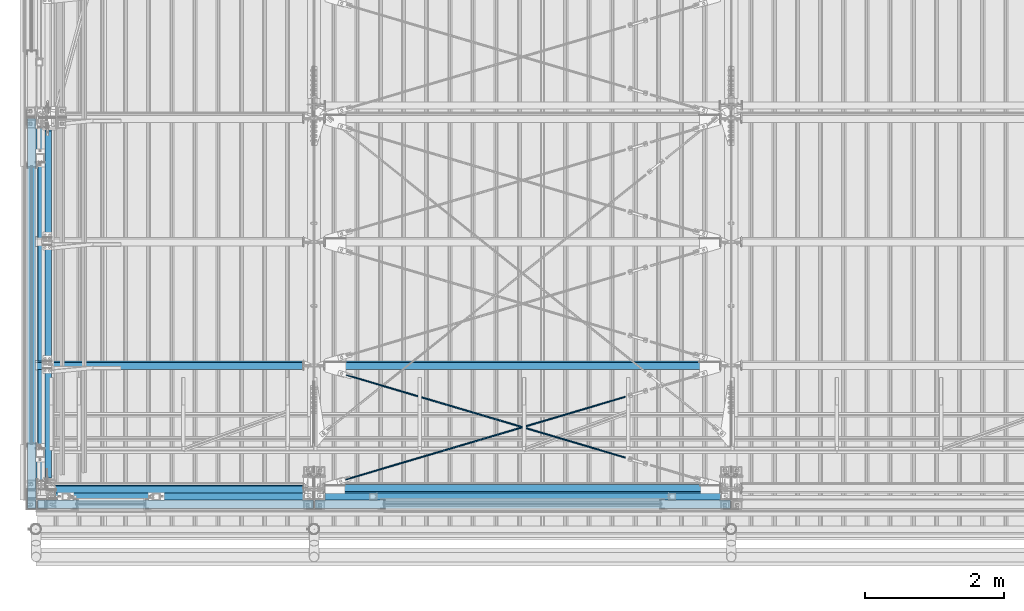
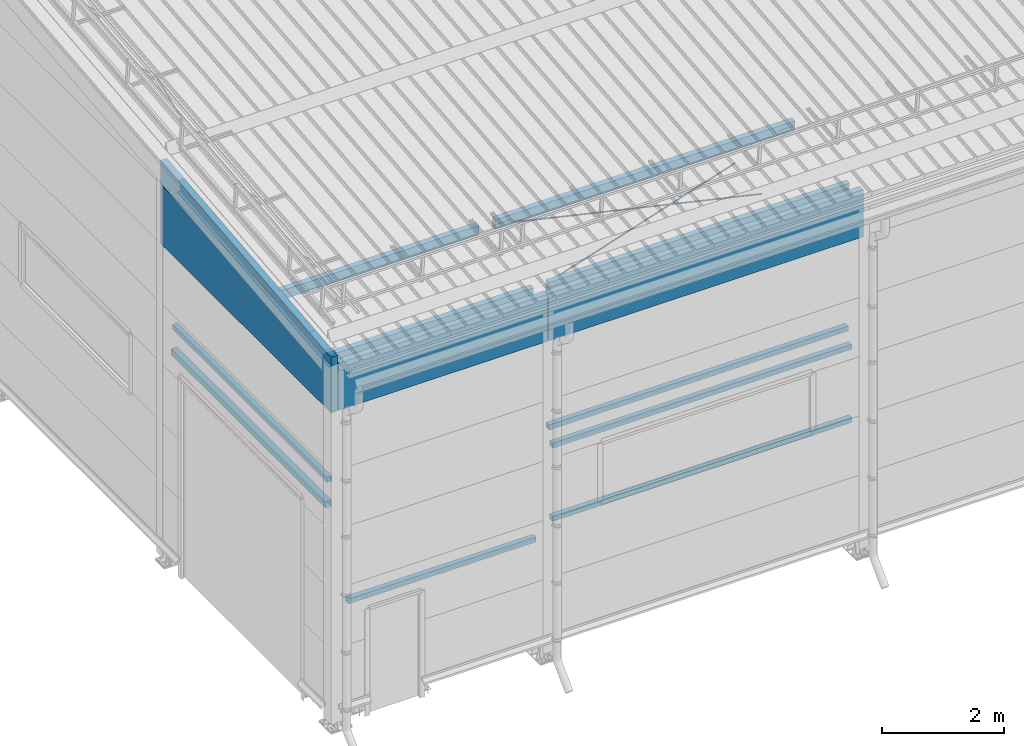
# One storey, part 240 of 709: 17 beams, 6 openings, 17 elements without a shape of their own.
"""IFC4 building model written with IfcOpenShell, lengths in millimetres."""

from ifc_helpers import new_model, si_unit, direction, frame, origin_with_axes, place, context, subcontext, project, spatial, line, indexed_curve, outline, extrude, polygons, material, element, aggregate, save


model = new_model("IFC4")

# Units and contexts
model_context = context("Model", 3, precision=0.2, world=origin_with_axes(), true_north=direction((0.0, 1.0)))
body_context = subcontext(model_context, "Body", "Model", "MODEL_VIEW")
reference_context = subcontext(model_context, "Reference", "Model", "MODEL_VIEW")
ifc_project = project(units=[si_unit("LENGTHUNIT", "METRE", prefix="MILLI"), si_unit("AREAUNIT", "SQUARE_METRE"), si_unit("VOLUMEUNIT", "CUBIC_METRE"), si_unit("MASSUNIT", "GRAM", prefix="KILO"), si_unit("TIMEUNIT", "SECOND"), si_unit("PLANEANGLEUNIT", "RADIAN"), si_unit("SOLIDANGLEUNIT", "STERADIAN"), si_unit("THERMODYNAMICTEMPERATUREUNIT", "DEGREE_CELSIUS"), si_unit("LUMINOUSINTENSITYUNIT", "LUMEN")], contexts=[model_context])

# Site, building, storey
site_placement = place(None, origin_with_axes())
site = spatial("IfcSite", under=ifc_project, at=site_placement, CompositionType="ELEMENT")
building_placement = place(site_placement, origin_with_axes())
building = spatial("IfcBuilding", under=site, at=building_placement, Name="Undefined", CompositionType="ELEMENT")
storey_placement = place(building_placement, origin_with_axes())
storey = spatial("IfcBuildingStorey", under=building, at=storey_placement, Name="Undefined", CompositionType="ELEMENT", Elevation=0.0)

# Assembly, beam
assembly_1_placement = place(storey_placement, frame((162.5, 346.0, 6929.907), z_axis=(1.0, 0.0, 0.0), x_axis=(0.0, 0.9950371902, 0.099503719)))
assembly_1 = element("IfcElementAssembly", 1, at=assembly_1_placement, inside=storey)
ifc_material_1 = material(Name="C255-4", Category="STEEL")
beam_1_placement = place(assembly_1_placement, origin_with_axes())
beam_1 = element("IfcBeam", 2, at=beam_1_placement, material=ifc_material_1, ObjectType="451", context=body_context, shape_type="Tessellation", body=[
    polygons([(-15.12818, -124.0, -62.0), (-15.12818, -116.0, -62.0), (4996.83432, -116.0, -62.0), (4996.83432, -124.0, -62.0), (-15.12818, -116.0, -2.5), (4996.83432, -116.0, -2.5), (-15.12818, 116.0, -2.5), (4996.83432, 116.0, -2.5), (-15.12818, 116.0, -62.0), (4996.83432, 116.0, -62.0), (-15.12818, 124.0, -62.0), (4996.83432, 124.0, -62.0), (-15.12818, 124.0, 62.0), (4996.83432, 124.0, 62.0), (-15.12818, 116.0, 62.0), (4996.83432, 116.0, 62.0), (-15.12818, 116.0, 2.5), (4996.83432, 116.0, 2.5), (-15.12818, -116.0, 2.5), (4996.83432, -116.0, 2.5), (-15.12818, -116.0, 62.0), (4996.83432, -116.0, 62.0), (-15.12818, -124.0, 62.0), (4996.83432, -124.0, 62.0)], [[[1, 2, 3, 4]], [[2, 5, 6, 3]], [[5, 7, 8, 6]], [[7, 9, 10, 8]], [[9, 11, 12, 10]], [[11, 13, 14, 12]], [[13, 15, 16, 14]], [[15, 17, 18, 16]], [[17, 19, 20, 18]], [[19, 21, 22, 20]], [[21, 23, 24, 22]], [[23, 1, 4, 24]], [[6, 8, 10, 12, 14, 16, 18, 20, 22, 24, 4, 3]], [[23, 21, 19, 17, 15, 13, 11, 9, 7, 5, 2, 1]]], closed=True),
])
aggregate(assembly_1, [beam_1])

assembly_2_placement = place(storey_placement, frame((80.0, 5500.0, 4610.0), z_axis=(0.0, 0.0, -1.0), x_axis=(0.0, -1.0, 0.0)))
assembly_2 = element("IfcElementAssembly", 3, at=assembly_2_placement, inside=storey)
ifc_material_2 = material(Name="C355", Category="STEEL")
beam_2_placement = place(assembly_2_placement, origin_with_axes())
beam_2 = element("IfcBeam", 4, at=beam_2_placement, material=ifc_material_2, ObjectType="494", context=body_context, shape_type="Tessellation", body=[
    polygons([(142.5, -50.0, 50.0), (142.5, -50.0, -50.0), (5222.0, -50.0, -50.0), (5222.0, -50.0, 50.0), (142.5, 50.0, 50.0), (5222.0, 50.0, 50.0), (142.5, 50.0, -50.0), (5222.0, 50.0, -50.0), (142.5, -47.0, 47.0), (142.5, 47.0, 47.0), (5222.0, 47.0, 47.0), (5222.0, -47.0, 47.0), (142.5, -47.0, -47.0), (5222.0, -47.0, -47.0), (142.5, 47.0, -47.0), (5222.0, 47.0, -47.0)], [[[1, 2, 3, 4]], [[5, 1, 4, 6]], [[7, 5, 6, 8]], [[2, 7, 8, 3]], [[1, 5, 7, 2], [15, 10, 9, 13]], [[9, 10, 11, 12]], [[13, 9, 12, 14]], [[15, 13, 14, 16]], [[10, 15, 16, 11]], [[3, 8, 6, 4], [14, 12, 11, 16]]], closed=True),
])
aggregate(assembly_2, [beam_2])

assembly_3_placement = place(storey_placement, frame((60.0, 5500.0, 4120.0), z_axis=(0.0, 0.0, -1.0), x_axis=(0.0, -1.0, 0.0)))
assembly_3 = element("IfcElementAssembly", 5, at=assembly_3_placement, inside=storey)
ifc_material_3 = material(Name="C255", Category="STEEL")
beam_3_placement = place(assembly_3_placement, origin_with_axes())
beam_3 = element("IfcBeam", 6, at=beam_3_placement, material=ifc_material_3, ObjectType="531", context=body_context, shape_type="Tessellation", body=[
    polygons([(142.5, -60.0, 60.0), (142.5, -60.0, -60.0), (5222.0, -60.0, -60.0), (5222.0, -60.0, 60.0), (142.5, 60.0, 60.0), (5222.0, 60.0, 60.0), (142.5, 60.0, -60.0), (5222.0, 60.0, -60.0), (142.5, -56.0, 56.0), (142.5, 56.0, 56.0), (5222.0, 56.0, 56.0), (5222.0, -56.0, 56.0), (142.5, -56.0, -56.0), (5222.0, -56.0, -56.0), (142.5, 56.0, -56.0), (5222.0, 56.0, -56.0)], [[[1, 2, 3, 4]], [[5, 1, 4, 6]], [[7, 5, 6, 8]], [[2, 7, 8, 3]], [[1, 5, 7, 2], [15, 10, 9, 13]], [[9, 10, 11, 12]], [[13, 9, 12, 14]], [[15, 13, 14, 16]], [[10, 15, 16, 11]], [[3, 8, 6, 4], [14, 12, 11, 16]]], closed=True),
])
aggregate(assembly_3, [beam_3])

assembly_4_placement = place(storey_placement, frame((80.0, 50.0, 2250.0), z_axis=(0.0, 0.0, -1.0), x_axis=(1.0, 0.0, 0.0)))
assembly_4 = element("IfcElementAssembly", 7, at=assembly_4_placement, inside=storey)
beam_4_placement = place(assembly_4_placement, origin_with_axes())
beam_4 = element("IfcBeam", 8, at=beam_4_placement, material=ifc_material_2, ObjectType="542", context=body_context, shape_type="Tessellation", body=[
    polygons([(3765.0, 50.0, 50.0), (3765.0, 50.0, -50.0), (198.0, 50.0, -50.0), (198.0, 50.0, 50.0), (3765.0, -50.0, 50.0), (198.0, -50.0, 50.0), (3765.0, -50.0, -50.0), (198.0, -50.0, -50.0), (3765.0, 47.0, -47.0), (3765.0, 47.0, 47.0), (198.0, 47.0, 47.0), (198.0, 47.0, -47.0), (3765.0, -47.0, -47.0), (198.0, -47.0, -47.0), (3765.0, -47.0, 47.0), (198.0, -47.0, 47.0)], [[[1, 2, 3, 4]], [[5, 1, 4, 6]], [[7, 5, 6, 8]], [[2, 7, 8, 3]], [[1, 5, 7, 2], [10, 9, 13, 15]], [[9, 10, 11, 12]], [[13, 9, 12, 14]], [[15, 13, 14, 16]], [[10, 15, 16, 11]], [[8, 6, 4, 3], [14, 12, 11, 16]]], closed=True),
])
aggregate(assembly_4, [beam_4])

assembly_5_placement = place(storey_placement, frame((4000.0, 50.0, 2550.0), z_axis=(0.0, 0.0, -1.0), x_axis=(1.0, 0.0, 0.0)))
assembly_5 = element("IfcElementAssembly", 9, at=assembly_5_placement, inside=storey)
beam_5_placement = place(assembly_5_placement, origin_with_axes())
beam_5 = element("IfcBeam", 10, at=beam_5_placement, material=ifc_material_2, ObjectType="545", context=body_context, shape_type="Tessellation", body=[
    polygons([(155.0, -47.0, -47.0), (155.0, -47.0, 47.0), (5845.0, -47.0, 47.0), (5845.0, -47.0, -47.0), (155.0, 47.0, 47.0), (5845.0, 47.0, 47.0), (155.0, 47.0, -47.0), (5845.0, 47.0, -47.0), (155.0, -50.0, -50.0), (155.0, 50.0, -50.0), (5845.0, 50.0, -50.0), (5845.0, -50.0, -50.0), (155.0, 50.0, 50.0), (5845.0, 50.0, 50.0), (155.0, -50.0, 50.0), (5845.0, -50.0, 50.0)], [[[1, 2, 3, 4]], [[2, 5, 6, 3]], [[5, 7, 8, 6]], [[7, 1, 4, 8]], [[9, 10, 11, 12]], [[10, 13, 14, 11]], [[13, 15, 16, 14]], [[15, 9, 12, 16]], [[14, 16, 12, 11], [6, 8, 4, 3]], [[15, 13, 10, 9], [7, 5, 2, 1]]], closed=True),
])
aggregate(assembly_5, [beam_5])

assembly_6_placement = place(storey_placement, frame((4000.0, 50.0, 4020.0), z_axis=(0.0, 0.0, -1.0), x_axis=(1.0, 0.0, 0.0)))
assembly_6 = element("IfcElementAssembly", 11, at=assembly_6_placement, inside=storey)
beam_6_placement = place(assembly_6_placement, origin_with_axes())
beam_6 = element("IfcBeam", 12, at=beam_6_placement, material=ifc_material_2, ObjectType="545", context=body_context, shape_type="Tessellation", body=[
    polygons([(155.0, -47.0, -47.0), (155.0, -47.0, 47.0), (5845.0, -47.0, 47.0), (5845.0, -47.0, -47.0), (155.0, 47.0, 47.0), (5845.0, 47.0, 47.0), (155.0, 47.0, -47.0), (5845.0, 47.0, -47.0), (155.0, -50.0, -50.0), (155.0, 50.0, -50.0), (5845.0, 50.0, -50.0), (5845.0, -50.0, -50.0), (155.0, 50.0, 50.0), (5845.0, 50.0, 50.0), (155.0, -50.0, 50.0), (5845.0, -50.0, 50.0)], [[[1, 2, 3, 4]], [[2, 5, 6, 3]], [[5, 7, 8, 6]], [[7, 1, 4, 8]], [[9, 10, 11, 12]], [[10, 13, 14, 11]], [[13, 15, 16, 14]], [[15, 9, 12, 16]], [[14, 16, 12, 11], [6, 8, 4, 3]], [[15, 13, 10, 9], [7, 5, 2, 1]]], closed=True),
])
aggregate(assembly_6, [beam_6])

assembly_7_placement = place(storey_placement, frame((4000.0, 173.0, 4310.0), z_axis=(0.0, 0.0, -1.0), x_axis=(1.0, 0.0, 0.0)))
assembly_7 = element("IfcElementAssembly", 13, at=assembly_7_placement, inside=storey)
beam_7_placement = place(assembly_7_placement, origin_with_axes())
beam_7 = element("IfcBeam", 14, at=beam_7_placement, material=ifc_material_2, ObjectType="546", context=body_context, shape_type="Tessellation", body=[
    polygons([(155.0, -47.0, -47.0), (155.0, -47.0, 47.0), (5845.0, -47.0, 47.0), (5845.0, -47.0, -47.0), (155.0, 47.0, 47.0), (5845.0, 47.0, 47.0), (155.0, 47.0, -47.0), (5845.0, 47.0, -47.0), (155.0, -50.0, -50.0), (155.0, 50.0, -50.0), (5845.0, 50.0, -50.0), (5845.0, -50.0, -50.0), (155.0, 50.0, 50.0), (5845.0, 50.0, 50.0), (155.0, -50.0, 50.0), (5845.0, -50.0, 50.0)], [[[1, 2, 3, 4]], [[2, 5, 6, 3]], [[5, 7, 8, 6]], [[7, 1, 4, 8]], [[9, 10, 11, 12]], [[10, 13, 14, 11]], [[13, 15, 16, 14]], [[15, 9, 12, 16]], [[14, 16, 12, 11], [6, 8, 4, 3]], [[15, 13, 10, 9], [7, 5, 2, 1]]], closed=True),
])
aggregate(assembly_7, [beam_7])

# Assembly, beam, voiding feature
assembly_8_placement = place(storey_placement, frame((4000.0, 159.15434, 7152.41945), z_axis=(0.2852311229, -0.9537021177, -0.0953702118), x_axis=(0.9584587662, 0.2838155751, 0.028381558)))
assembly_8 = element("IfcElementAssembly", 15, at=assembly_8_placement, inside=storey)
ifc_material_4 = material(Name="C355-5", Category="STEEL")
beam_8_placement = place(assembly_8_placement, origin_with_axes())
beam_8 = element("IfcBeam", 16, at=beam_8_placement, material=ifc_material_4, ObjectType="568", context=body_context, shape_type="Tessellation", body=[
    polygons([(4850.05021, 7.36121, 4.25), (4850.05021, 6.01041, 6.01041), (4850.05021, 4.25, 7.36122), (4850.05021, 2.19996, 8.21037), (4850.05021, 0.0, 8.5), (4850.05021, -2.19996, 8.21037), (4850.05021, -4.25, 7.36122), (4850.05021, -6.01041, 6.01041), (4850.05021, -7.36122, 4.25), (4850.05021, -8.21037, 2.19996), (4850.05021, -8.5, 0.0), (4850.05021, -8.21037, -2.19996), (4850.05021, -7.36122, -4.25), (4850.05021, -6.01041, -6.01041), (4850.05021, -4.25, -7.36121), (4850.05021, -2.19996, -8.21037), (4850.05021, 0.0, -8.5), (4850.05021, 2.19996, -8.21037), (4850.05021, 4.25, -7.36121), (4850.05021, 6.01041, -6.01041), (4850.05021, 7.36121, -4.25), (4850.05021, 8.21037, -2.19996), (4850.05021, 8.5, 0.0), (4850.05021, 8.21037, 2.19996), (4670.05021, 8.21037, 2.19996), (4670.05021, 7.36121, 4.25), (4670.05021, 6.01041, 6.01041), (4670.05021, 4.25, 7.36122), (4670.05021, 2.19996, 8.21037), (4670.05021, 0.0, 8.5), (4670.05021, -2.19996, 8.21037), (4670.05021, -4.25, 7.36122), (4670.05021, -6.01041, 6.01041), (4670.05021, -7.36122, 4.25), (4670.05021, -8.21037, 2.19996), (4670.05021, -8.5, 0.0), (4670.05021, -8.21037, -2.19996), (4670.05021, -7.36122, -4.25), (4670.05021, -6.01041, -6.01041), (4670.05021, -4.25, -7.36121), (4670.05021, -2.19996, -8.21037), (4670.05021, 0.0, -8.5), (4670.05021, 2.19996, -8.21037), (4670.05021, 4.25, -7.36121), (4670.05021, 6.01041, -6.01041), (4670.05021, 7.36121, -4.25), (4670.05021, 8.21037, -2.19996), (4670.05021, 8.5, 0.0), (4670.05021, 10.0, 0.0), (4670.05021, 9.65926, 2.58819), (4670.05021, 8.66025, 5.0), (4670.05021, 7.07107, 7.07107), (4670.05021, 5.0, 8.66025), (4670.05021, 2.58819, 9.65926), (4670.05021, 0.0, 10.0), (4670.05021, -2.58819, 9.65926), (4670.05021, -5.0, 8.66025), (4670.05021, -7.07107, 7.07107), (4670.05021, -8.66025, 5.0), (4670.05021, -9.65926, 2.58819), (4670.05021, -10.0, 0.0), (4670.05021, -9.65926, -2.58819), (4670.05021, -8.66025, -5.0), (4670.05021, -7.07107, -7.07107), (4670.05021, -5.0, -8.66025), (4670.05021, -2.58819, -9.65926), (4670.05021, 0.0, -10.0), (4670.05021, 2.58819, -9.65926), (4670.05021, 5.0, -8.66025), (4670.05021, 7.07107, -7.07107), (4670.05021, 8.66025, -5.0), (4670.05021, 9.65926, -2.58819), (468.0251, 2.58819, 9.65926), (468.0251, 5.0, 8.66025), (468.0251, 7.07107, 7.07107), (468.0251, 8.66025, 5.0), (468.0251, 9.65926, 2.58819), (468.0251, 10.0, 0.0), (468.0251, 9.65926, -2.58819), (468.0251, 8.66025, -5.0), (468.0251, 7.07107, -7.07107), (468.0251, 5.0, -8.66025), (468.0251, 2.58819, -9.65926), (468.0251, 0.0, -10.0), (468.0251, -2.58819, -9.65926), (468.0251, -5.0, -8.66025), (468.0251, -7.07107, -7.07107), (468.0251, -8.66025, -5.0), (468.0251, -9.65926, -2.58819), (468.0251, -10.0, 0.0), (468.0251, -9.65926, 2.58819), (468.0251, -8.66025, 5.0), (468.0251, -7.07107, 7.07107), (468.0251, -5.0, 8.66025), (468.0251, -2.58819, 9.65926), (468.0251, 0.0, 10.0)], [[[1, 2, 3, 4, 5, 6, 7, 8, 9, 10, 11, 12, 13, 14, 15, 16, 17, 18, 19, 20, 21, 22, 23, 24]], [[24, 25, 26, 1]], [[1, 26, 27, 2]], [[2, 27, 28, 3]], [[3, 28, 29, 4]], [[4, 29, 30, 5]], [[5, 30, 31, 6]], [[6, 31, 32, 7]], [[7, 32, 33, 8]], [[8, 33, 34, 9]], [[9, 34, 35, 10]], [[10, 35, 36, 11]], [[11, 36, 37, 12]], [[12, 37, 38, 13]], [[13, 38, 39, 14]], [[14, 39, 40, 15]], [[15, 40, 41, 16]], [[16, 41, 42, 17]], [[17, 42, 43, 18]], [[18, 43, 44, 19]], [[19, 44, 45, 20]], [[20, 45, 46, 21]], [[21, 46, 47, 22]], [[22, 47, 48, 23]], [[23, 48, 25, 24]], [[49, 50, 51, 52, 53, 54, 55, 56, 57, 58, 59, 60, 61, 62, 63, 64, 65, 66, 67, 68, 69, 70, 71, 72], [47, 46, 45, 44, 43, 42, 41, 40, 39, 38, 37, 36, 35, 34, 33, 32, 31, 30, 29, 28, 27, 26, 25, 48]], [[73, 74, 75, 76, 77, 78, 79, 80, 81, 82, 83, 84, 85, 86, 87, 88, 89, 90, 91, 92, 93, 94, 95, 96]], [[79, 78, 49, 72]], [[80, 79, 72, 71]], [[81, 80, 71, 70]], [[82, 81, 70, 69]], [[83, 82, 69, 68]], [[84, 83, 68, 67]], [[85, 84, 67, 66]], [[86, 85, 66, 65]], [[87, 86, 65, 64]], [[88, 87, 64, 63]], [[89, 88, 63, 62]], [[90, 89, 62, 61]], [[91, 90, 61, 60]], [[92, 91, 60, 59]], [[93, 92, 59, 58]], [[94, 93, 58, 57]], [[95, 94, 57, 56]], [[96, 95, 56, 55]], [[73, 96, 55, 54]], [[74, 73, 54, 53]], [[75, 74, 53, 52]], [[76, 75, 52, 51]], [[77, 76, 51, 50]], [[78, 77, 50, 49]]], closed=True),
])
voiding_feature_1_placement = place(beam_8_placement, frame((4850.05021, 0.0, 0.0), z_axis=(0.0, 1.0, 0.0), x_axis=(-1.0, 0.0, 0.0)))
element("IfcVoidingFeature", 17, at=voiding_feature_1_placement, cuts=beam_8, PredefinedType="HOLE", context=reference_context, identifier="Reference", shape_type="SolidModel", body=[
    extrude(outline(indexed_curve([(10.5, 0.0), (10.14222, 2.7176), (9.09327, 5.25), (7.42462, 7.42462), (5.25, 9.09327), (2.7176, 10.14222), (0.0, 10.5), (-2.7176, 10.14222), (-5.25, 9.09327), (-7.42462, 7.42462), (-9.09327, 5.25), (-10.14222, 2.7176), (-10.5, 0.0), (-10.14222, -2.7176), (-9.09327, -5.25), (-7.42462, -7.42462), (-5.25, -9.09327), (-2.7176, -10.14222), (0.0, -10.5), (2.7176, -10.14222), (5.25, -9.09327), (7.42462, -7.42462), (9.09327, -5.25), (10.14222, -2.7176)], segments=[line(1, 2, 3, 4, 5, 6, 7, 8, 9, 10, 11, 12, 13, 14, 15, 16, 17, 18, 19, 20, 21, 22, 23, 24, 1)])), frame((0.0, 0.0, 0.0), z_axis=(-1.0, 0.0, 0.0), x_axis=(0.0, 0.0, 1.0)), (0.0, 0.0, -1.0), 180.0),
])
aggregate(assembly_8, [beam_8])

assembly_9_placement = place(storey_placement, frame((4000.0, 1935.85409, 7330.08943), z_axis=(-0.2852311229, -0.9537021177, -0.0953702118), x_axis=(0.9584587662, -0.2838155751, -0.028381558)))
assembly_9 = element("IfcElementAssembly", 18, at=assembly_9_placement, inside=storey)
beam_9_placement = place(assembly_9_placement, origin_with_axes())
beam_9 = element("IfcBeam", 19, at=beam_9_placement, material=ifc_material_4, ObjectType="570", context=body_context, shape_type="Tessellation", body=[
    polygons([(4850.05021, 7.36122, 4.25), (4850.05021, 6.01041, 6.01041), (4850.05021, 4.25, 7.36121), (4850.05021, 2.19996, 8.21037), (4850.05021, 0.0, 8.5), (4850.05021, -2.19996, 8.21037), (4850.05021, -4.25, 7.36121), (4850.05021, -6.01041, 6.01041), (4850.05021, -7.36121, 4.25), (4850.05021, -8.21037, 2.19996), (4850.05021, -8.5, 0.0), (4850.05021, -8.21037, -2.19996), (4850.05021, -7.36121, -4.25), (4850.05021, -6.01041, -6.01041), (4850.05021, -4.25, -7.36122), (4850.05021, -2.19996, -8.21037), (4850.05021, 0.0, -8.5), (4850.05021, 2.19996, -8.21037), (4850.05021, 4.25, -7.36122), (4850.05021, 6.01041, -6.01041), (4850.05021, 7.36122, -4.25), (4850.05021, 8.21037, -2.19996), (4850.05021, 8.5, 0.0), (4850.05021, 8.21037, 2.19996), (4670.05021, 8.21037, 2.19996), (4670.05021, 7.36122, 4.25), (4670.05021, 6.01041, 6.01041), (4670.05021, 4.25, 7.36121), (4670.05021, 2.19996, 8.21037), (4670.05021, 0.0, 8.5), (4670.05021, -2.19996, 8.21037), (4670.05021, -4.25, 7.36121), (4670.05021, -6.01041, 6.01041), (4670.05021, -7.36121, 4.25), (4670.05021, -8.21037, 2.19996), (4670.05021, -8.5, 0.0), (4670.05021, -8.21037, -2.19996), (4670.05021, -7.36121, -4.25), (4670.05021, -6.01041, -6.01041), (4670.05021, -4.25, -7.36122), (4670.05021, -2.19996, -8.21037), (4670.05021, 0.0, -8.5), (4670.05021, 2.19996, -8.21037), (4670.05021, 4.25, -7.36122), (4670.05021, 6.01041, -6.01041), (4670.05021, 7.36122, -4.25), (4670.05021, 8.21037, -2.19996), (4670.05021, 8.5, 0.0), (4670.05021, 10.0, 0.0), (4670.05021, 9.65926, 2.58819), (4670.05021, 8.66025, 5.0), (4670.05021, 7.07107, 7.07107), (4670.05021, 5.0, 8.66025), (4670.05021, 2.58819, 9.65926), (4670.05021, 0.0, 10.0), (4670.05021, -2.58819, 9.65926), (4670.05021, -5.0, 8.66025), (4670.05021, -7.07107, 7.07107), (4670.05021, -8.66025, 5.0), (4670.05021, -9.65926, 2.58819), (4670.05021, -10.0, 0.0), (4670.05021, -9.65926, -2.58819), (4670.05021, -8.66025, -5.0), (4670.05021, -7.07107, -7.07107), (4670.05021, -5.0, -8.66025), (4670.05021, -2.58819, -9.65926), (4670.05021, 0.0, -10.0), (4670.05021, 2.58819, -9.65926), (4670.05021, 5.0, -8.66025), (4670.05021, 7.07107, -7.07107), (4670.05021, 8.66025, -5.0), (4670.05021, 9.65926, -2.58819), (483.0251, 2.58819, 9.65926), (483.0251, 5.0, 8.66025), (483.0251, 7.07107, 7.07107), (483.0251, 8.66025, 5.0), (483.0251, 9.65926, 2.58819), (483.0251, 10.0, 0.0), (483.0251, 9.65926, -2.58819), (483.0251, 8.66025, -5.0), (483.0251, 7.07107, -7.07107), (483.0251, 5.0, -8.66025), (483.0251, 2.58819, -9.65926), (483.0251, 0.0, -10.0), (483.0251, -2.58819, -9.65926), (483.0251, -5.0, -8.66025), (483.0251, -7.07107, -7.07107), (483.0251, -8.66025, -5.0), (483.0251, -9.65926, -2.58819), (483.0251, -10.0, 0.0), (483.0251, -9.65926, 2.58819), (483.0251, -8.66025, 5.0), (483.0251, -7.07107, 7.07107), (483.0251, -5.0, 8.66025), (483.0251, -2.58819, 9.65926), (483.0251, 0.0, 10.0)], [[[1, 2, 3, 4, 5, 6, 7, 8, 9, 10, 11, 12, 13, 14, 15, 16, 17, 18, 19, 20, 21, 22, 23, 24]], [[24, 25, 26, 1]], [[1, 26, 27, 2]], [[2, 27, 28, 3]], [[3, 28, 29, 4]], [[4, 29, 30, 5]], [[5, 30, 31, 6]], [[6, 31, 32, 7]], [[7, 32, 33, 8]], [[8, 33, 34, 9]], [[9, 34, 35, 10]], [[10, 35, 36, 11]], [[11, 36, 37, 12]], [[12, 37, 38, 13]], [[13, 38, 39, 14]], [[14, 39, 40, 15]], [[15, 40, 41, 16]], [[16, 41, 42, 17]], [[17, 42, 43, 18]], [[18, 43, 44, 19]], [[19, 44, 45, 20]], [[20, 45, 46, 21]], [[21, 46, 47, 22]], [[22, 47, 48, 23]], [[23, 48, 25, 24]], [[49, 50, 51, 52, 53, 54, 55, 56, 57, 58, 59, 60, 61, 62, 63, 64, 65, 66, 67, 68, 69, 70, 71, 72], [47, 46, 45, 44, 43, 42, 41, 40, 39, 38, 37, 36, 35, 34, 33, 32, 31, 30, 29, 28, 27, 26, 25, 48]], [[73, 74, 75, 76, 77, 78, 79, 80, 81, 82, 83, 84, 85, 86, 87, 88, 89, 90, 91, 92, 93, 94, 95, 96]], [[79, 78, 49, 72]], [[80, 79, 72, 71]], [[81, 80, 71, 70]], [[82, 81, 70, 69]], [[83, 82, 69, 68]], [[84, 83, 68, 67]], [[85, 84, 67, 66]], [[86, 85, 66, 65]], [[87, 86, 65, 64]], [[88, 87, 64, 63]], [[89, 88, 63, 62]], [[90, 89, 62, 61]], [[91, 90, 61, 60]], [[92, 91, 60, 59]], [[93, 92, 59, 58]], [[94, 93, 58, 57]], [[95, 94, 57, 56]], [[96, 95, 56, 55]], [[73, 96, 55, 54]], [[74, 73, 54, 53]], [[75, 74, 53, 52]], [[76, 75, 52, 51]], [[77, 76, 51, 50]], [[78, 77, 50, 49]]], closed=True),
])
voiding_feature_2_placement = place(beam_9_placement, frame((4850.05021, 0.0, 0.0), z_axis=(0.0, 1.0, 0.0), x_axis=(-1.0, 0.0, 0.0)))
element("IfcVoidingFeature", 20, at=voiding_feature_2_placement, cuts=beam_9, PredefinedType="HOLE", context=reference_context, identifier="Reference", shape_type="SolidModel", body=[
    extrude(outline(indexed_curve([(10.5, 0.0), (10.14222, 2.7176), (9.09327, 5.25), (7.42462, 7.42462), (5.25, 9.09327), (2.7176, 10.14222), (0.0, 10.5), (-2.7176, 10.14222), (-5.25, 9.09327), (-7.42462, 7.42462), (-9.09327, 5.25), (-10.14222, 2.7176), (-10.5, 0.0), (-10.14222, -2.7176), (-9.09327, -5.25), (-7.42462, -7.42462), (-5.25, -9.09327), (-2.7176, -10.14222), (0.0, -10.5), (2.7176, -10.14222), (5.25, -9.09327), (7.42462, -7.42462), (9.09327, -5.25), (10.14222, -2.7176)], segments=[line(1, 2, 3, 4, 5, 6, 7, 8, 9, 10, 11, 12, 13, 14, 15, 16, 17, 18, 19, 20, 21, 22, 23, 24, 1)])), frame((0.0, 0.0, 0.0), z_axis=(-1.0, 0.0, 0.0), x_axis=(0.0, 0.0, 1.0)), (0.0, 0.0, -1.0), 180.0),
])
aggregate(assembly_9, [beam_9])

# Assembly, beam
assembly_10_placement = place(storey_placement, frame((0.0, 159.95037, 7144.41925), z_axis=(0.0, 0.9950371902, 0.099503719), x_axis=(1.0, 0.0, 0.0)))
assembly_10 = element("IfcElementAssembly", 21, at=assembly_10_placement, inside=storey)
beam_10_placement = place(assembly_10_placement, origin_with_axes())
beam_10 = element("IfcBeam", 22, at=beam_10_placement, material=ifc_material_2, ObjectType="562", context=body_context, shape_type="Tessellation", body=[
    polygons([(3855.0, 100.0, 50.0), (3855.0, 100.0, -50.0), (28.0, 100.0, -50.0), (28.0, 100.0, 50.0), (3855.0, -100.0, 50.0), (28.0, -100.0, 50.0), (3855.0, -100.0, -50.0), (28.0, -100.0, -50.0), (3855.0, 96.0, -46.0), (3855.0, 96.0, 46.0), (28.0, 96.0, 46.0), (28.0, 96.0, -46.0), (3855.0, -96.0, -46.0), (28.0, -96.0, -46.0), (3855.0, -96.0, 46.0), (28.0, -96.0, 46.0)], [[[1, 2, 3, 4]], [[5, 1, 4, 6]], [[7, 5, 6, 8]], [[2, 7, 8, 3]], [[1, 5, 7, 2], [10, 9, 13, 15]], [[9, 10, 11, 12]], [[13, 9, 12, 14]], [[15, 13, 14, 16]], [[10, 15, 16, 11]], [[8, 6, 4, 3], [14, 12, 11, 16]]], closed=True),
])
aggregate(assembly_10, [beam_10])

assembly_11_placement = place(storey_placement, frame((0.0, 1936.65012, 7322.08923), z_axis=(0.0, 0.9950371902, 0.099503719), x_axis=(1.0, 0.0, 0.0)))
assembly_11 = element("IfcElementAssembly", 23, at=assembly_11_placement, inside=storey)
beam_11_placement = place(assembly_11_placement, origin_with_axes())
beam_11 = element("IfcBeam", 24, at=beam_11_placement, material=ifc_material_2, ObjectType="563", context=body_context, shape_type="Tessellation", body=[
    polygons([(3845.0, 100.0, 50.0), (3845.0, 100.0, -50.0), (8.0, 100.0, -50.0), (8.0, 100.0, 50.0), (3845.0, -100.0, 50.0), (8.0, -100.0, 50.0), (3845.0, -100.0, -50.0), (8.0, -100.0, -50.0), (3845.0, 96.0, -46.0), (3845.0, 96.0, 46.0), (8.0, 96.0, 46.0), (8.0, 96.0, -46.0), (3845.0, -96.0, -46.0), (8.0, -96.0, -46.0), (3845.0, -96.0, 46.0), (8.0, -96.0, 46.0)], [[[1, 2, 3, 4]], [[5, 1, 4, 6]], [[7, 5, 6, 8]], [[2, 7, 8, 3]], [[1, 5, 7, 2], [10, 9, 13, 15]], [[9, 10, 11, 12]], [[13, 9, 12, 14]], [[15, 13, 14, 16]], [[10, 15, 16, 11]], [[8, 6, 4, 3], [14, 12, 11, 16]]], closed=True),
])
aggregate(assembly_11, [beam_11])

# Assembly, beam, voiding features
assembly_12_placement = place(storey_placement, frame((4000.0, 158.95533, 7154.40952), z_axis=(0.0, 0.9950371902, 0.099503719), x_axis=(1.0, 0.0, 0.0)))
assembly_12 = element("IfcElementAssembly", 25, at=assembly_12_placement, inside=storey)
beam_12_placement = place(assembly_12_placement, origin_with_axes())
beam_12 = element("IfcBeam", 26, at=beam_12_placement, material=ifc_material_2, ObjectType="565", context=body_context, shape_type="Tessellation", body=[
    polygons([(5855.0, 5.0, 50.0), (5855.0, 5.0, 46.0), (5557.75102, 5.0, 46.0), (5557.75102, 5.0, 50.0), (5557.75102, 15.0, 46.0), (5557.75102, 15.0, 50.0), (5855.0, 15.0, 50.0), (5855.0, 15.0, 46.0), (5855.0, 5.0, -46.0), (5855.0, 5.0, -50.0), (5557.75102, 5.0, -50.0), (5557.75102, 5.0, -46.0), (5557.75102, 15.0, -50.0), (5557.75102, 15.0, -46.0), (5855.0, 15.0, -46.0), (5855.0, 15.0, -50.0), (145.0, 86.0, 46.0), (145.0, 86.0, -46.0), (5855.0, 86.0, -46.0), (5855.0, 86.0, 46.0), (5855.0, -86.0, 46.0), (145.0, -86.0, 46.0), (145.0, 5.0, 46.0), (442.24898, 5.0, 46.0), (442.24898, 15.0, 46.0), (145.0, 15.0, 46.0), (145.0, -86.0, -46.0), (5855.0, -86.0, -46.0), (145.0, 15.0, -46.0), (145.0, 15.0, -50.0), (442.24898, 15.0, -50.0), (442.24898, 15.0, -46.0), (442.24898, 5.0, -50.0), (442.24898, 5.0, -46.0), (145.0, 5.0, -50.0), (145.0, 5.0, -46.0), (145.0, -90.0, -50.0), (145.0, -90.0, 50.0), (145.0, 5.0, 50.0), (442.24898, 5.0, 50.0), (442.24898, 15.0, 50.0), (145.0, 15.0, 50.0), (145.0, 90.0, 50.0), (145.0, 90.0, -50.0), (5855.0, 90.0, 50.0), (5855.0, 90.0, -50.0), (5855.0, -90.0, -50.0), (5855.0, -90.0, 50.0)], [[[1, 2, 3, 4]], [[4, 3, 5, 6]], [[7, 6, 5, 8]], [[9, 10, 11, 12]], [[12, 11, 13, 14]], [[15, 14, 13, 16]], [[17, 18, 19, 20]], [[3, 2, 21, 22, 23, 24, 25, 26, 17, 20, 8, 5]], [[27, 22, 21, 28]], [[29, 30, 31, 32]], [[32, 31, 33, 34]], [[34, 33, 35, 36]], [[22, 27, 36, 35, 37, 38, 39, 23]], [[40, 24, 23, 39]], [[41, 25, 24, 40]], [[42, 26, 25, 41]], [[43, 44, 30, 29, 18, 17, 26, 42]], [[44, 43, 45, 46]], [[20, 19, 15, 16, 46, 45, 7, 8]], [[11, 10, 47, 37, 35, 33, 31, 30, 44, 46, 16, 13]], [[38, 37, 47, 48]], [[45, 43, 42, 41, 40, 39, 38, 48, 1, 4, 6, 7]], [[48, 47, 10, 9, 28, 21, 2, 1]], [[19, 18, 29, 32, 34, 36, 27, 28, 9, 12, 14, 15]]], closed=True),
])
voiding_feature_3_placement = place(beam_12_placement, frame((145.0, 10.0, -70.0), z_axis=(0.0, -1.0, 0.0), x_axis=(1.0, 0.0, 0.0)))
element("IfcVoidingFeature", 27, at=voiding_feature_3_placement, cuts=beam_12, PredefinedType="HOLE", context=reference_context, identifier="Reference", shape_type="SolidModel", body=[
    extrude(outline(indexed_curve([(0.0, 0.0), (297.24898, 0.0), (297.24898, 154.66006), (271.57818, 240.92135), (0.0, 160.10144)], segments=[line(1, 2, 3, 4, 5, 1)])), frame((0.0, 0.0, 5.0), z_axis=(0.0, 0.0, 1.0), x_axis=(1.0, 0.0, 0.0)), (0.0, 0.0, -1.0), 10.0),
])
voiding_feature_4_placement = place(beam_12_placement, frame((5557.75102, 10.0, -70.0), z_axis=(0.0, -1.0, 0.0), x_axis=(1.0, 0.0, 0.0)))
element("IfcVoidingFeature", 28, at=voiding_feature_4_placement, cuts=beam_12, PredefinedType="HOLE", context=reference_context, identifier="Reference", shape_type="SolidModel", body=[
    extrude(outline(indexed_curve([(0.0, 0.0), (297.24898, 0.0), (297.24898, 160.10144), (25.6708, 240.92135), (0.0, 154.66006)], segments=[line(1, 2, 3, 4, 5, 1)])), frame((0.0, 0.0, 5.0), z_axis=(0.0, 0.0, 1.0), x_axis=(1.0, 0.0, 0.0)), (0.0, 0.0, -1.0), 10.0),
])
aggregate(assembly_12, [beam_12])

assembly_13_placement = place(storey_placement, frame((4000.0, 1936.65012, 7322.12913), z_axis=(0.0, 0.9950371902, 0.099503719), x_axis=(1.0, 0.0, 0.0)))
assembly_13 = element("IfcElementAssembly", 29, at=assembly_13_placement, inside=storey)
beam_13_placement = place(assembly_13_placement, origin_with_axes())
beam_13 = element("IfcBeam", 30, at=beam_13_placement, material=ifc_material_2, ObjectType="566", context=body_context, shape_type="Tessellation", body=[
    polygons([(5845.0, -5.0, 50.0), (5845.0, -5.0, 46.0), (5543.37414, -5.0, 46.0), (5543.37414, -5.0, 50.0), (5543.37414, 5.0, 46.0), (5543.37414, 5.0, 50.0), (5845.00055, 5.0, 50.0), (5845.0, 5.0, 46.0), (5845.0, -5.0, -46.0), (5845.0, -5.0, -50.0), (5543.37413, -5.0, -50.0), (5543.37413, -5.0, -46.0), (5543.37413, 5.0, -50.0), (5543.37413, 5.0, -46.0), (5845.00055, 5.0, -46.0), (5845.0, 5.0, -50.0), (155.0, 96.0, 46.0), (155.0, 96.0, -46.0), (5845.0, 96.0, -46.0), (5845.0, 96.0, 46.0), (5845.0, -96.0, 46.0), (155.0, -96.0, 46.0), (155.0, -5.0, 46.0), (456.62587, -5.0, 46.0), (456.62587, 5.0, 46.0), (155.0, 5.0, 46.0), (155.0, -96.0, -46.0), (5845.0, -96.0, -46.0), (155.0, 5.0, -46.0), (155.0, 5.0, -50.0), (456.62587, 5.0, -50.0), (456.62587, 5.0, -46.0), (456.62587, -5.0, -50.0), (456.62587, -5.0, -46.0), (155.0, -5.0, -50.0), (155.0, -5.0, -46.0), (155.0, -100.0, -50.0), (155.0, -100.0, 50.0), (155.0, -5.0, 50.0), (456.62587, -5.0, 50.0), (456.62587, 5.0, 50.0), (155.0, 5.0, 50.0), (155.0, 100.0, 50.0), (155.0, 100.0, -50.0), (5845.0, 100.0, 50.0), (5845.0, 100.0, -50.0), (5845.0, -100.0, -50.0), (5845.0, -100.0, 50.0)], [[[1, 2, 3, 4]], [[4, 3, 5, 6]], [[7, 6, 5, 8]], [[9, 10, 11, 12]], [[12, 11, 13, 14]], [[15, 14, 13, 16]], [[17, 18, 19, 20]], [[3, 2, 21, 22, 23, 24, 25, 26, 17, 20, 8, 5]], [[27, 22, 21, 28]], [[29, 30, 31, 32]], [[32, 31, 33, 34]], [[34, 33, 35, 36]], [[22, 27, 36, 35, 37, 38, 39, 23]], [[40, 24, 23, 39]], [[41, 25, 24, 40]], [[42, 26, 25, 41]], [[43, 44, 30, 29, 18, 17, 26, 42]], [[44, 43, 45, 46]], [[20, 19, 15, 16, 46, 45, 7, 8]], [[11, 10, 47, 37, 35, 33, 31, 30, 44, 46, 16, 13]], [[38, 37, 47, 48]], [[45, 43, 42, 41, 40, 39, 38, 48, 1, 4, 6, 7]], [[48, 47, 10, 9, 28, 21, 2, 1]], [[19, 18, 29, 32, 34, 36, 27, 28, 9, 12, 14, 15]]], closed=True),
])
voiding_feature_5_placement = place(beam_13_placement, frame((154.99945, 0.0, 93.07721), z_axis=(0.0, -1.0, 0.0), x_axis=(0.0, 0.0, -1.0)))
element("IfcVoidingFeature", 31, at=voiding_feature_5_placement, cuts=beam_13, Name="PLATE", PredefinedType="HOLE", context=reference_context, identifier="Reference", shape_type="SolidModel", body=[
    extrude(outline(indexed_curve([(0.0, 0.0), (186.15442, 0.0), (268.27702, 275.95562), (182.01573, 301.62642), (4.13868, 301.62642), (-82.1226, 275.95562)], segments=[line(1, 2, 3, 4, 5, 6, 1)])), frame((0.0, 0.0, 5.0), z_axis=(0.0, 0.0, 1.0), x_axis=(1.0, 0.0, 0.0)), (0.0, 0.0, -1.0), 10.0),
])
voiding_feature_6_placement = place(beam_13_placement, frame((5845.00055, 0.0, -93.07721), z_axis=(0.0, -1.0, 0.0), x_axis=(0.0, 0.0, 1.0)))
element("IfcVoidingFeature", 32, at=voiding_feature_6_placement, cuts=beam_13, Name="PLATE", PredefinedType="HOLE", context=reference_context, identifier="Reference", shape_type="SolidModel", body=[
    extrude(outline(indexed_curve([(0.0, 0.0), (186.15442, 0.0), (268.27702, 275.95562), (182.01573, 301.62642), (4.13868, 301.62642), (-82.1226, 275.95562)], segments=[line(1, 2, 3, 4, 5, 6, 1)])), frame((0.0, 0.0, 5.0), z_axis=(0.0, 0.0, 1.0), x_axis=(1.0, 0.0, 0.0)), (0.0, 0.0, -1.0), 10.0),
])
aggregate(assembly_13, [beam_13])

# Assembly, beam
assembly_14_placement = place(storey_placement, frame((20.0, -60.0, 6845.0), z_axis=(0.0, 0.0, -1.0), x_axis=(1.0, 0.0, 0.0)))
assembly_14 = element("IfcElementAssembly", 33, at=assembly_14_placement, inside=storey)
ifc_material_5 = material(Name="Insulation", Category="Insulation")
beam_14_placement = place(assembly_14_placement, origin_with_axes())
beam_14 = element("IfcBeam", 34, at=beam_14_placement, material=ifc_material_5, ObjectType="P-103", context=body_context, shape_type="Tessellation", body=[
    polygons([(0.0, 60.0, 595.0), (0.0, -60.0, 595.0), (3970.0, -60.0, 595.0), (3970.0, 60.0, 595.0), (3970.0, 60.0, -351.923), (0.0, 60.0, -351.923), (0.0, -60.0, -351.923), (3970.0, -60.0, -351.923)], [[[1, 2, 3, 4]], [[1, 4, 5, 6]], [[2, 1, 6, 7]], [[3, 2, 7, 8]], [[4, 3, 8, 5]], [[7, 6, 5, 8]]], closed=True),
])
aggregate(assembly_14, [beam_14])

assembly_15_placement = place(storey_placement, frame((4010.0, -60.0, 6845.0), z_axis=(0.0, 0.0, -1.0), x_axis=(1.0, 0.0, 0.0)))
assembly_15 = element("IfcElementAssembly", 35, at=assembly_15_placement, inside=storey)
beam_15_placement = place(assembly_15_placement, origin_with_axes())
beam_15 = element("IfcBeam", 36, at=beam_15_placement, material=ifc_material_5, ObjectType="P-108", context=body_context, shape_type="Tessellation", body=[
    polygons([(0.0, 60.0, 595.0), (0.0, -60.0, 595.0), (5980.0, -60.0, 595.0), (5980.0, 60.0, 595.0), (5980.0, 60.0, -351.923), (0.0, 60.0, -351.923), (0.0, -60.0, -351.923), (5980.0, -60.0, -351.923)], [[[1, 2, 3, 4]], [[1, 4, 5, 6]], [[2, 1, 6, 7]], [[3, 2, 7, 8]], [[4, 3, 8, 5]], [[7, 6, 5, 8]]], closed=True),
])
aggregate(assembly_15, [beam_15])

assembly_16_placement = place(storey_placement, frame((-60.0, -120.0, 6845.0), z_axis=(0.0, 0.0, -1.0), x_axis=(0.0, 1.0, 0.0)))
assembly_16 = element("IfcElementAssembly", 37, at=assembly_16_placement, inside=storey)
beam_16_placement = place(assembly_16_placement, origin_with_axes())
beam_16 = element("IfcBeam", 38, at=beam_16_placement, material=ifc_material_5, ObjectType="P-131", context=body_context, shape_type="Tessellation", body=[
    polygons([(0.0, 60.0, 595.0), (0.0, -60.0, 595.0), (5610.0, -60.0, 595.0), (5610.0, 60.0, 595.0), (5610.0, -60.0, -595.0), (5610.0, 60.0, -595.0), (723.29, 60.0, -595.0), (0.0, 60.0, -522.671), (0.0, -60.0, -522.671), (723.29, -60.0, -595.0)], [[[1, 2, 3, 4]], [[4, 3, 5, 6]], [[1, 4, 6, 7, 8]], [[2, 1, 8, 9]], [[5, 3, 2, 9, 10]], [[6, 5, 10, 7]], [[9, 8, 7, 10]]], closed=True),
])
aggregate(assembly_16, [beam_16])

assembly_17_placement = place(storey_placement, frame((-60.0, -120.0, 8035.0), z_axis=(0.0, 0.0, -1.0), x_axis=(0.0, 1.0, 0.0)))
assembly_17 = element("IfcElementAssembly", 39, at=assembly_17_placement, inside=storey)
beam_17_placement = place(assembly_17_placement, origin_with_axes())
beam_17 = element("IfcBeam", 40, at=beam_17_placement, material=ifc_material_5, ObjectType="P-132", context=body_context, shape_type="Tessellation", body=[
    polygons([(5610.0, 60.0, 595.0), (5610.0, 60.0, 106.329), (723.29, 60.0, 595.0), (5610.0, -60.0, 595.0), (723.29, -60.0, 595.0), (5610.0, -60.0, 106.329)], [[[1, 2, 3]], [[4, 1, 3, 5]], [[4, 5, 6]], [[1, 4, 6, 2]], [[5, 3, 2, 6]]], closed=True),
])
aggregate(assembly_17, [beam_17])

save(model, "model.ifc")
